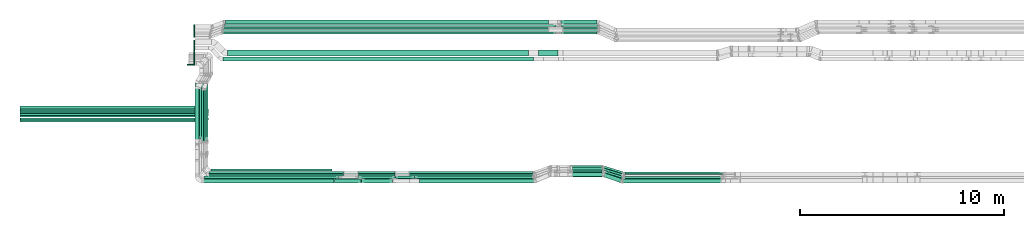
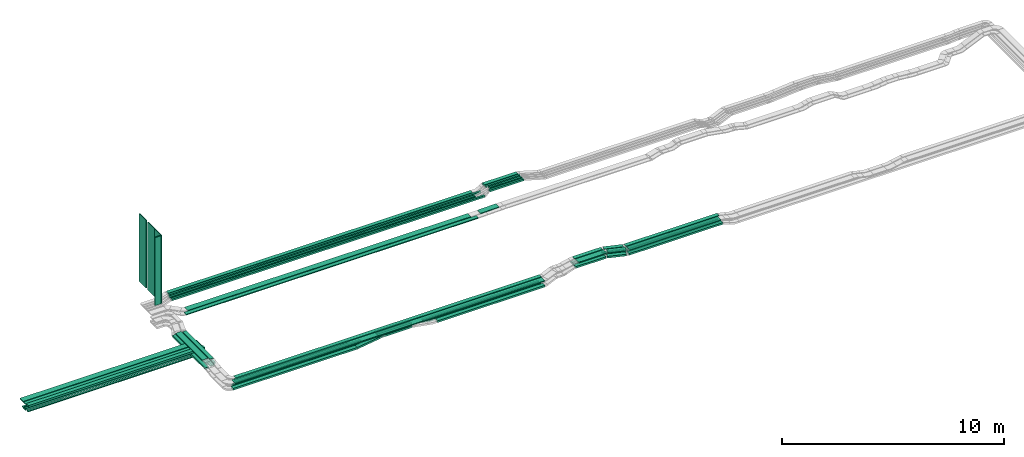
# One storey, part 1 of 31: 65 flow segments.
"""IFC2X3 building model written with IfcOpenShell, lengths in millimetres."""

from ifc_helpers import new_model, entity, si_unit, converted_unit, derived_unit, direction, frame, frame_2d, origin, origin_2d_with_axis, place, context, subcontext, project, spatial, rectangle, extrude, type_object, element, save


model = new_model("IFC2X3")

# Units and contexts
model_context = context("Model", 3, precision=0.01, world=origin(), true_north=direction((6.12303176911189e-17, 1.0)))
body_context = subcontext(model_context, "Body", "Model", "MODEL_VIEW")
ifc_project = project(units=[si_unit("LENGTHUNIT", "METRE", prefix="MILLI"), si_unit("AREAUNIT", "SQUARE_METRE"), si_unit("VOLUMEUNIT", "CUBIC_METRE"), converted_unit("PLANEANGLEUNIT", "DEGREE", entity("IfcRatioMeasure", 0.0174532925199433), si_unit("PLANEANGLEUNIT", "RADIAN"), dimensions=[0, 0, 0, 0, 0, 0, 0]), si_unit("MASSUNIT", "GRAM", prefix="KILO"), derived_unit("MASSDENSITYUNIT", [(si_unit("MASSUNIT", "GRAM", prefix="KILO"), 1), (si_unit("LENGTHUNIT", "METRE"), -3)]), derived_unit("MOMENTOFINERTIAUNIT", [(si_unit("LENGTHUNIT", "METRE"), 4)]), si_unit("TIMEUNIT", "SECOND"), si_unit("FREQUENCYUNIT", "HERTZ"), si_unit("THERMODYNAMICTEMPERATUREUNIT", "DEGREE_CELSIUS"), derived_unit("THERMALTRANSMITTANCEUNIT", [(si_unit("MASSUNIT", "GRAM", prefix="KILO"), 1), (si_unit("THERMODYNAMICTEMPERATUREUNIT", "KELVIN"), -1), (si_unit("TIMEUNIT", "SECOND"), -3)]), derived_unit("VOLUMETRICFLOWRATEUNIT", [(si_unit("LENGTHUNIT", "METRE"), 3), (si_unit("TIMEUNIT", "SECOND"), -1)]), derived_unit("MASSFLOWRATEUNIT", [(si_unit("MASSUNIT", "GRAM", prefix="KILO"), 1), (si_unit("TIMEUNIT", "SECOND"), -1)]), derived_unit("ROTATIONALFREQUENCYUNIT", [(si_unit("TIMEUNIT", "SECOND"), -1)]), si_unit("ELECTRICCURRENTUNIT", "AMPERE"), si_unit("ELECTRICVOLTAGEUNIT", "VOLT"), si_unit("POWERUNIT", "WATT"), si_unit("FORCEUNIT", "NEWTON", prefix="KILO"), si_unit("ILLUMINANCEUNIT", "LUX"), si_unit("LUMINOUSFLUXUNIT", "LUMEN"), si_unit("LUMINOUSINTENSITYUNIT", "CANDELA"), derived_unit("USERDEFINED", [(si_unit("MASSUNIT", "GRAM", prefix="KILO"), -1), (si_unit("LENGTHUNIT", "METRE"), -2), (si_unit("TIMEUNIT", "SECOND"), 3), (si_unit("LUMINOUSFLUXUNIT", "LUMEN"), 1)]), derived_unit("LINEARVELOCITYUNIT", [(si_unit("LENGTHUNIT", "METRE"), 1), (si_unit("TIMEUNIT", "SECOND"), -1)]), si_unit("PRESSUREUNIT", "PASCAL"), derived_unit("USERDEFINED", [(si_unit("LENGTHUNIT", "METRE"), -2), (si_unit("MASSUNIT", "GRAM", prefix="KILO"), 1), (si_unit("TIMEUNIT", "SECOND"), -2)]), derived_unit("LINEARFORCEUNIT", [(si_unit("MASSUNIT", "GRAM", prefix="KILO"), 1), (si_unit("LENGTHUNIT", "METRE"), 1), (si_unit("TIMEUNIT", "SECOND"), -2), (si_unit("LENGTHUNIT", "METRE"), -1)]), derived_unit("PLANARFORCEUNIT", [(si_unit("MASSUNIT", "GRAM", prefix="KILO"), 1), (si_unit("LENGTHUNIT", "METRE"), 1), (si_unit("TIMEUNIT", "SECOND"), -2), (si_unit("LENGTHUNIT", "METRE"), -2)])], contexts=[model_context])

# Site, building, storey
site_placement = place(None, frame((0.0, -0.00077364408347762, 0.0)))
site = spatial("IfcSite", under=ifc_project, at=site_placement, CompositionType="ELEMENT")
building_placement = place(site_placement, origin())
building = spatial("IfcBuilding", under=site, at=building_placement, CompositionType="ELEMENT")
storey_placement = place(building_placement, frame((0.0, 0.0, 15900.0)))
storey = spatial("IfcBuildingStorey", under=building, at=storey_placement, CompositionType="ELEMENT", Elevation=15900.0)

# Flow segments
cable_carrier_segment_type_1 = type_object("IfcCableCarrierSegmentType", PredefinedType="CABLETRAYSEGMENT")
flow_segment_1_placement = place(storey_placement, frame((17073.5, 10315.0806700198, 2607.25805153974)))
element("IfcFlowSegment", 1, at=flow_segment_1_placement, inside=storey, type_object=cable_carrier_segment_type_1, context=body_context, shape_type="SweptSolid", body=[
    extrude(rectangle(XDim=2780.65043288834, YDim=99.9999999999989, at=frame_2d((1.02318153949454e-12, 1.08357767203415e-12), x_axis=(1.0, 0.0))), frame((50.0, 1390.32521644417, 0.0), z_axis=(0.0, 0.0, 1.0), x_axis=(0.0, -1.0, 0.0)), (0.0, 0.0, 1.0), 99.9999999999989),
])
flow_segment_2_placement = place(storey_placement, frame((16853.5, 10214.4421477542, 2607.25805153974)))
element("IfcFlowSegment", 2, at=flow_segment_2_placement, inside=storey, type_object=cable_carrier_segment_type_1, context=body_context, shape_type="SweptSolid", body=[
    extrude(rectangle(XDim=2881.28895515389, YDim=99.9999999999989, at=frame_2d((-1.02318153949454e-12, 0.0), x_axis=(1.0, 0.0))), frame((50.0, 1440.64447757695, 0.0), z_axis=(0.0, 0.0, 1.0), x_axis=(0.0, -1.0, 0.0)), (0.0, 0.0, 1.0), 49.9999999999995),
])
flow_segment_3_placement = place(storey_placement, frame((8000.0, 11314.4937501787, 2532.25805153974)))
element("IfcFlowSegment", 3, at=flow_segment_3_placement, inside=storey, type_object=cable_carrier_segment_type_1, context=body_context, shape_type="SweptSolid", body=[
    extrude(rectangle(XDim=9200.0, YDim=99.9999999999989, at=frame_2d((0.0, -1.08357767203415e-12), x_axis=(1.0, 0.0))), frame((4600.0, 50.0, 0.0)), (0.0, 0.0, 1.0), 50.0000000000016),
])
flow_segment_4_placement = place(storey_placement, frame((7981.51536011307, 11524.4937501787, 2507.25805153974)))
element("IfcFlowSegment", 4, at=flow_segment_4_placement, inside=storey, type_object=cable_carrier_segment_type_1, context=body_context, shape_type="SweptSolid", body=[
    extrude(rectangle(XDim=9218.48463988693, YDim=99.9999999999989, at=frame_2d((4.54747350886464e-13, -1.08357767203415e-12), x_axis=(1.0, 0.0))), frame((4609.24231994347, 50.0, 0.0)), (0.0, 0.0, 1.0), 99.9999999999989),
])
flow_segment_5_placement = place(storey_placement, frame((7981.51536011307, 11638.053841593, 2507.25805153974)))
element("IfcFlowSegment", 5, at=flow_segment_5_placement, inside=storey, type_object=cable_carrier_segment_type_1, context=body_context, shape_type="SweptSolid", body=[
    extrude(rectangle(XDim=9218.48463988694, YDim=99.9999999999989, at=origin_2d_with_axis()), frame((4609.24231994347, 50.0, 0.0)), (0.0, 0.0, 1.0), 50.0000000000016),
])
flow_segment_6_placement = place(storey_placement, frame((8000.0, 11748.053841593, 2507.25805153974)))
element("IfcFlowSegment", 6, at=flow_segment_6_placement, inside=storey, type_object=cable_carrier_segment_type_1, context=body_context, shape_type="SweptSolid", body=[
    extrude(rectangle(XDim=9200.0, YDim=99.9999999999989, at=origin_2d_with_axis()), frame((4600.0, 50.0, 0.0)), (0.0, 0.0, 1.0), 50.0000000000016),
])
flow_segment_7_placement = place(storey_placement, frame((7970.69792091004, 11214.3508300614, 2865.0)))
element("IfcFlowSegment", 7, at=flow_segment_7_placement, inside=storey, type_object=cable_carrier_segment_type_1, context=body_context, shape_type="SweptSolid", body=[
    extrude(rectangle(XDim=9180.0, YDim=200.000000000002, at=frame_2d((-9.09494701772928e-13, -1.08713038571295e-12), x_axis=(1.0, 0.0))), frame((4590.0, 100.0, 0.0)), (0.0, 0.0, 1.0), 100.000000000001),
])
flow_segment_8_placement = place(storey_placement, frame((7970.69792091004, 11450.6171299992, 2865.0)))
element("IfcFlowSegment", 8, at=flow_segment_8_placement, inside=storey, type_object=cable_carrier_segment_type_1, context=body_context, shape_type="SweptSolid", body=[
    extrude(rectangle(XDim=9180.0, YDim=199.999999999998, at=frame_2d((-9.09494701772928e-13, 1.08002495835535e-12), x_axis=(1.0, 0.0))), frame((4590.0, 100.0, 0.0)), (0.0, 0.0, 1.0), 50.0000000000016),
])
flow_segment_9_placement = place(storey_placement, frame((7970.69792091004, 11685.6171299992, 2865.0)))
element("IfcFlowSegment", 9, at=flow_segment_9_placement, inside=storey, type_object=cable_carrier_segment_type_1, context=body_context, shape_type="SweptSolid", body=[
    extrude(rectangle(XDim=9180.0, YDim=300.000000000001, at=frame_2d((-9.09494701772928e-13, 0.0), x_axis=(1.0, 0.0))), frame((4590.0, 150.0, 0.0)), (0.0, 0.0, 1.0), 50.0000000000016),
])
flow_segment_10_placement = place(storey_placement, frame((24529.6232754685, 8454.96624585791, 2685.0)))
element("IfcFlowSegment", 10, at=flow_segment_10_placement, inside=storey, type_object=cable_carrier_segment_type_1, context=body_context, shape_type="SweptSolid", body=[
    extrude(rectangle(XDim=1786.26303875484, YDim=99.9999999999989, at=frame_2d((-2.1600499167107e-12, -5.40012479177676e-13), x_axis=(1.0, 0.0))), frame((893.131519377424, 50.0, 0.0), z_axis=(0.0, 0.0, 1.0), x_axis=(-1.0, 0.0, 0.0)), (0.0, 0.0, 1.0), 99.9999999999989),
])
flow_segment_11_placement = place(storey_placement, frame((24526.241285069, 8695.50215480076, 2685.0)))
element("IfcFlowSegment", 11, at=flow_segment_11_placement, inside=storey, type_object=cable_carrier_segment_type_1, context=body_context, shape_type="SweptSolid", body=[
    extrude(rectangle(XDim=1802.89625010228, YDim=99.9999999999989, at=frame_2d((-2.1600499167107e-12, -1.08357767203415e-12), x_axis=(1.0, 0.0))), frame((901.448125051143, 50.0, 0.0), z_axis=(0.0, 0.0, 1.0), x_axis=(-1.0, 0.0, 0.0)), (0.0, 0.0, 1.0), 50.0000000000016),
])
flow_segment_12_placement = place(storey_placement, frame((27287.2400617418, 8454.96624585788, 2500.0)))
element("IfcFlowSegment", 12, at=flow_segment_12_placement, inside=storey, type_object=cable_carrier_segment_type_1, context=body_context, shape_type="SweptSolid", body=[
    extrude(rectangle(XDim=5758.36690365423, YDim=99.9999999999989, at=frame_2d((-4.32009983342141e-12, -1.08357767203415e-12), x_axis=(1.0, 0.0))), frame((2879.18345182712, 50.0, 0.0)), (0.0, 0.0, 1.0), 99.9999999999968),
])
flow_segment_13_placement = place(storey_placement, frame((27017.8049788234, 8695.50215480076, 2500.0)))
element("IfcFlowSegment", 13, at=flow_segment_13_placement, inside=storey, type_object=cable_carrier_segment_type_1, context=body_context, shape_type="SweptSolid", body=[
    extrude(rectangle(XDim=6063.03813263292, YDim=99.9999999999989, at=frame_2d((-2.27373675443232e-12, 5.40012479177676e-13), x_axis=(1.0, 0.0))), frame((3031.51906631646, 50.0, 0.0)), (0.0, 0.0, 1.0), 50.0000000000016),
])
flow_segment_14_placement = place(storey_placement, frame((26318.6258556337, 8454.96624585791, 2502.07202741318)))
element("IfcFlowSegment", 14, at=flow_segment_14_placement, inside=storey, type_object=cable_carrier_segment_type_1, context=body_context, shape_type="SweptSolid", body=[
    extrude(rectangle(XDim=99.9999999999993, YDim=99.9999999999989, at=frame_2d((-2.1280754936015e-12, 0.0), x_axis=(1.0, 0.0))), frame((9.4705436558692, 50.0, 231.761049279451), z_axis=(0.981897917883988, 0.0, -0.189410873117385), x_axis=(0.189410873117385, 0.0, 0.981897917883988)), (0.0, 0.0, 1.0), 964.391063611438),
])
flow_segment_15_placement = place(storey_placement, frame((37472.0379725514, 8224.96624585787, 2710.0)))
element("IfcFlowSegment", 15, at=flow_segment_15_placement, inside=storey, type_object=cable_carrier_segment_type_1, context=body_context, shape_type="SweptSolid", body=[
    extrude(rectangle(XDim=4888.31327705013, YDim=200.0, at=frame_2d((2.04636307898909e-12, -5.47117906535277e-13), x_axis=(1.0, 0.0))), frame((2444.15663852507, 100.0, 0.0), z_axis=(0.0, 0.0, 1.0), x_axis=(-1.0, 0.0, 0.0)), (0.0, 0.0, 1.0), 99.9999999999968),
])
flow_segment_16_placement = place(storey_placement, frame((37505.9951751335, 8550.14880665484, 2960.0)))
element("IfcFlowSegment", 16, at=flow_segment_16_placement, inside=storey, type_object=cable_carrier_segment_type_1, context=body_context, shape_type="SweptSolid", body=[
    extrude(rectangle(XDim=4857.14151539678, YDim=200.0, at=frame_2d((4.32009983342141e-12, 1.08713038571295e-12), x_axis=(1.0, 0.0))), frame((2428.57075769839, 100.0, 0.0), z_axis=(0.0, 0.0, 1.0), x_axis=(-1.0, 0.0, 0.0)), (0.0, 0.0, 1.0), 50.0000000000016),
])
flow_segment_17_placement = place(storey_placement, frame((37499.7965530135, 8215.14880665484, 2960.0)))
element("IfcFlowSegment", 17, at=flow_segment_17_placement, inside=storey, type_object=cable_carrier_segment_type_1, context=body_context, shape_type="SweptSolid", body=[
    extrude(rectangle(XDim=4763.81493661313, YDim=299.999999999999, at=frame_2d((-4.32009983342141e-12, 5.40012479177676e-13), x_axis=(1.0, 0.0))), frame((2381.90746830657, 150.0, 0.0), z_axis=(0.0, 0.0, 1.0), x_axis=(-1.0, 0.0, 0.0)), (0.0, 0.0, 1.0), 50.0000000000016),
])
flow_segment_18_placement = place(storey_placement, frame((37556.0888944561, 8434.96624585786, 2710.0)))
element("IfcFlowSegment", 18, at=flow_segment_18_placement, inside=storey, type_object=cable_carrier_segment_type_1, context=body_context, shape_type="SweptSolid", body=[
    extrude(rectangle(XDim=4808.31327705014, YDim=99.9999999999989, at=frame_2d((-2.27373675443232e-12, 1.08357767203415e-12), x_axis=(1.0, 0.0))), frame((2404.15663852507, 50.0, 0.0), z_axis=(0.0, 0.0, 1.0), x_axis=(-1.0, 0.0, 0.0)), (0.0, 0.0, 1.0), 99.9999999999989),
])
flow_segment_19_placement = place(storey_placement, frame((37576.499239162, 8654.96624585788, 2710.60211095118)))
element("IfcFlowSegment", 19, at=flow_segment_19_placement, inside=storey, type_object=cable_carrier_segment_type_1, context=body_context, shape_type="SweptSolid", body=[
    extrude(rectangle(XDim=4789.76682509452, YDim=100.000000000001, at=frame_2d((0.0, 5.43565192856477e-13), x_axis=(1.0, 0.0))), frame((2394.88341254726, 50.0, 0.0), z_axis=(0.0, 0.0, 1.0), x_axis=(-1.0, 0.0, 0.0)), (0.0, 0.0, 1.0), 50.0000000000016),
])
flow_segment_20_placement = place(storey_placement, frame((34904.8847391636, 8985.14880665487, 2710.60211095118)))
element("IfcFlowSegment", 20, at=flow_segment_20_placement, inside=storey, type_object=cable_carrier_segment_type_1, context=body_context, shape_type="SweptSolid", body=[
    extrude(rectangle(XDim=1535.81415113666, YDim=100.000000000001, at=frame_2d((2.21689333557151e-12, -5.43565192856477e-13), x_axis=(1.0, 0.0))), frame((767.907075568328, 50.0, 0.0)), (0.0, 0.0, 1.0), 50.0000000000016),
])
flow_segment_21_placement = place(storey_placement, frame((36519.0529819506, 8243.65287049761, 2710.0)))
element("IfcFlowSegment", 21, at=flow_segment_21_placement, inside=storey, type_object=cable_carrier_segment_type_1, context=body_context, shape_type="SweptSolid", body=[
    extrude(rectangle(XDim=885.621574951497, YDim=200.000000000006, at=frame_2d((-2.04636307898909e-12, -6.96331881044898e-13), x_axis=(1.0, 0.0))), frame((451.542171609579, 236.313375360288, 0.0), z_axis=(0.0, 0.0, 1.0), x_axis=(-0.947523036731155, 0.319687495632485, 0.0)), (0.0, 0.0, 1.0), 99.9999999999989),
])
flow_segment_22_placement = place(storey_placement, frame((36528.6751324388, 8567.92914182516, 2960.0)))
element("IfcFlowSegment", 22, at=flow_segment_22_placement, inside=storey, type_object=cable_carrier_segment_type_1, context=body_context, shape_type="SweptSolid", body=[
    extrude(rectangle(XDim=911.680400926984, YDim=200.000000000001, at=frame_2d((1.70530256582424e-13, -5.11590769747272e-13), x_axis=(1.0, 0.0))), frame((464.286871152508, 237.219664829701, 0.0), z_axis=(0.0, 0.0, 1.0), x_axis=(-0.950090398751314, 0.311974733272694, 0.0)), (0.0, 0.0, 1.0), 50.0000000000016),
])
flow_segment_23_placement = place(storey_placement, frame((36540.5349178205, 8239.60370277755, 2960.0)))
element("IfcFlowSegment", 23, at=flow_segment_23_placement, inside=storey, type_object=cable_carrier_segment_type_1, context=body_context, shape_type="SweptSolid", body=[
    extrude(rectangle(XDim=857.94012161665, YDim=299.999999999997, at=origin_2d_with_axis()), frame((454.427085770818, 280.545103877309, 0.0), z_axis=(0.0, 0.0, 1.0), x_axis=(-0.946373728466921, 0.323073932819747, 0.0)), (0.0, 0.0, 1.0), 50.0000000000016),
])
flow_segment_24_placement = place(storey_placement, frame((16963.5, 10214.4421477542, 2607.25805153974)))
element("IfcFlowSegment", 24, at=flow_segment_24_placement, inside=storey, type_object=cable_carrier_segment_type_1, context=body_context, shape_type="SweptSolid", body=[
    extrude(rectangle(XDim=2881.28895515389, YDim=99.9999999999989, at=frame_2d((-1.02318153949454e-12, 0.0), x_axis=(1.0, 0.0))), frame((50.0, 1440.64447757695, 0.0), z_axis=(0.0, 0.0, 1.0), x_axis=(0.0, -1.0, 0.0)), (0.0, 0.0, 1.0), 49.9999999999995),
])
flow_segment_25_placement = place(storey_placement, frame((24526.241285069, 8575.50215480076, 2685.0)))
element("IfcFlowSegment", 25, at=flow_segment_25_placement, inside=storey, type_object=cable_carrier_segment_type_1, context=body_context, shape_type="SweptSolid", body=[
    extrude(rectangle(XDim=1802.89625010228, YDim=100.000000000001, at=frame_2d((-2.1600499167107e-12, 0.0), x_axis=(1.0, 0.0))), frame((901.448125051143, 50.0, 0.0), z_axis=(0.0, 0.0, 1.0), x_axis=(-1.0, 0.0, 0.0)), (0.0, 0.0, 1.0), 50.0000000000016),
])
flow_segment_26_placement = place(storey_placement, frame((27017.8049788234, 8575.50215480076, 2500.0)))
element("IfcFlowSegment", 26, at=flow_segment_26_placement, inside=storey, type_object=cable_carrier_segment_type_1, context=body_context, shape_type="SweptSolid", body=[
    extrude(rectangle(XDim=6046.06785474926, YDim=100.000000000001, at=frame_2d((2.27373675443232e-12, 5.43565192856477e-13), x_axis=(1.0, 0.0))), frame((3023.03392737463, 50.0, 0.0)), (0.0, 0.0, 1.0), 50.0000000000016),
])
flow_segment_27_placement = place(storey_placement, frame((24678.4849941389, 8224.96624585793, 2685.0)))
element("IfcFlowSegment", 27, at=flow_segment_27_placement, inside=storey, type_object=cable_carrier_segment_type_1, context=body_context, shape_type="SweptSolid", body=[
    extrude(rectangle(XDim=1528.31463009343, YDim=200.0, at=frame_2d((0.0, 5.47117906535277e-13), x_axis=(1.0, 0.0))), frame((764.157315046716, 100.0, 0.0), z_axis=(0.0, 0.0, 1.0), x_axis=(-1.0, 0.0, 0.0)), (0.0, 0.0, 1.0), 99.9999999999989),
])
flow_segment_28_placement = place(storey_placement, frame((27523.8169338614, 8224.96624585789, 2500.0)))
element("IfcFlowSegment", 28, at=flow_segment_28_placement, inside=storey, type_object=cable_carrier_segment_type_1, context=body_context, shape_type="SweptSolid", body=[
    extrude(rectangle(XDim=5594.92379897543, YDim=200.0, at=origin_2d_with_axis()), frame((2797.46189948771, 100.0, 0.0), z_axis=(0.0, 0.0, 1.0), x_axis=(-1.0, 0.0, 0.0)), (0.0, 0.0, 1.0), 99.9999999999968),
])
flow_segment_29_placement = place(storey_placement, frame((23349.8865776217, 8224.96624585793, 2501.44360529517)))
element("IfcFlowSegment", 29, at=flow_segment_29_placement, inside=storey, type_object=cable_carrier_segment_type_1, context=body_context, shape_type="SweptSolid", body=[
    extrude(rectangle(XDim=100.000000000002, YDim=200.0, at=origin_2d_with_axis()), frame((6.9201605015629, 100.0, 49.5187982349401), z_axis=(0.990375964698783, 0.0, 0.138403210031255), x_axis=(-0.138403210031255, 0.0, 0.990375964698783)), (0.0, 0.0, 1.0), 1324.96562263443),
])
flow_segment_30_placement = place(storey_placement, frame((36498.8529588234, 8446.30404606326, 2710.0)))
element("IfcFlowSegment", 30, at=flow_segment_30_placement, inside=storey, type_object=cable_carrier_segment_type_1, context=body_context, shape_type="SweptSolid", body=[
    extrude(rectangle(XDim=1027.17142103154, YDim=100.000000000001, at=frame_2d((-4.14956957683899e-12, -1.27897692436818e-12), x_axis=(1.0, 0.0))), frame((505.594720714333, 198.753480193109, 0.0), z_axis=(0.0, 0.0, 1.0), x_axis=(-0.955824550369197, 0.293937797691149, 0.0)), (0.0, 0.0, 1.0), 99.9999999999989),
])
flow_segment_31_placement = place(storey_placement, frame((36486.7453845043, 8556.30404606328, 2710.63734545373)))
element("IfcFlowSegment", 31, at=flow_segment_31_placement, inside=storey, type_object=cable_carrier_segment_type_1, context=body_context, shape_type="SweptSolid", body=[
    extrude(rectangle(XDim=1044.18182268543, YDim=99.9999999999993, at=frame_2d((2.1600499167107e-12, 1.17239551400417e-13), x_axis=(1.0, 0.0))), frame((513.724200470554, 201.253480193111, 0.0), z_axis=(0.0, 0.0, 1.0), x_axis=(0.955824550369191, -0.293937797691166, 0.0)), (0.0, 0.0, 1.0), 50.0000000000016),
])
flow_segment_32_placement = place(storey_placement, frame((36486.7453845043, 8666.30404606327, 2710.60211095119)))
element("IfcFlowSegment", 32, at=flow_segment_32_placement, inside=storey, type_object=cable_carrier_segment_type_1, context=body_context, shape_type="SweptSolid", body=[
    extrude(rectangle(XDim=1061.19222433936, YDim=100.000000000001, at=origin_2d_with_axis()), frame((521.853680226784, 203.753480193106, 0.0), z_axis=(0.0, 0.0, 1.0), x_axis=(-0.955824550369194, 0.293937797691157, 0.0)), (0.0, 0.0, 1.0), 50.0000000000016),
])
flow_segment_33_placement = place(storey_placement, frame((35019.5791049334, 8525.14880665488, 2960.0)))
element("IfcFlowSegment", 33, at=flow_segment_33_placement, inside=storey, type_object=cable_carrier_segment_type_1, context=body_context, shape_type="SweptSolid", body=[
    extrude(rectangle(XDim=1470.54834923566, YDim=299.999999999999, at=frame_2d((0.0, 5.40012479177676e-13), x_axis=(1.0, 0.0))), frame((735.274174617831, 150.0, 0.0), z_axis=(0.0, 0.0, 1.0), x_axis=(-1.0, 0.0, 0.0)), (0.0, 0.0, 1.0), 50.0000000000016),
])
flow_segment_34_placement = place(storey_placement, frame((35014.699398022, 8860.14880665487, 2960.0)))
element("IfcFlowSegment", 34, at=flow_segment_34_placement, inside=storey, type_object=cable_carrier_segment_type_1, context=body_context, shape_type="SweptSolid", body=[
    extrude(rectangle(XDim=1465.22943402716, YDim=200.0, at=frame_2d((0.0, -5.47117906535277e-13), x_axis=(1.0, 0.0))), frame((732.614717013582, 100.0, 0.0), z_axis=(0.0, 0.0, 1.0), x_axis=(-1.0, 0.0, 0.0)), (0.0, 0.0, 1.0), 50.0000000000016),
])
flow_segment_35_placement = place(storey_placement, frame((34902.3799835674, 8870.14880665489, 2710.63734545372)))
element("IfcFlowSegment", 35, at=flow_segment_35_placement, inside=storey, type_object=cable_carrier_segment_type_1, context=body_context, shape_type="SweptSolid", body=[
    extrude(rectangle(XDim=1538.31890673293, YDim=99.9999999999989, at=frame_2d((2.1600499167107e-12, 5.40012479177676e-13), x_axis=(1.0, 0.0))), frame((769.159453366469, 50.0, 0.0), z_axis=(0.0, 0.0, 1.0), x_axis=(-1.0, 0.0, 0.0)), (0.0, 0.0, 1.0), 50.0000000000016),
])
flow_segment_36_placement = place(storey_placement, frame((34899.5720400197, 8755.14880665487, 2710.0)))
element("IfcFlowSegment", 36, at=flow_segment_36_placement, inside=storey, type_object=cable_carrier_segment_type_1, context=body_context, shape_type="SweptSolid", body=[
    extrude(rectangle(XDim=1553.23442459964, YDim=99.9999999999989, at=frame_2d((0.0, 5.40012479177676e-13), x_axis=(1.0, 0.0))), frame((776.617212299821, 50.0, 0.0), z_axis=(0.0, 0.0, 1.0), x_axis=(-1.0, 0.0, 0.0)), (0.0, 0.0, 1.0), 99.9999999999989),
])
flow_segment_37_placement = place(storey_placement, frame((34897.2947679066, 8534.96624585791, 2710.0)))
element("IfcFlowSegment", 37, at=flow_segment_37_placement, inside=storey, type_object=cable_carrier_segment_type_1, context=body_context, shape_type="SweptSolid", body=[
    extrude(rectangle(XDim=1571.85756666243, YDim=200.0, at=frame_2d((0.0, -5.47117906535277e-13), x_axis=(1.0, 0.0))), frame((785.928783331213, 100.0, 0.0), z_axis=(0.0, 0.0, 1.0), x_axis=(-1.0, 0.0, 0.0)), (0.0, 0.0, 1.0), 99.9999999999989),
])
flow_segment_38_placement = place(storey_placement, frame((34443.0813938489, 15514.9939089947, 2834.95683445176)))
element("IfcFlowSegment", 38, at=flow_segment_38_placement, inside=storey, type_object=cable_carrier_segment_type_1, context=body_context, shape_type="SweptSolid", body=[
    extrude(rectangle(XDim=1770.27078387069, YDim=99.9999999999989, at=origin_2d_with_axis()), frame((885.135391935343, 50.0, 0.0), z_axis=(0.0, 0.0, 1.0), x_axis=(-1.0, 0.0, 0.0)), (0.0, 0.0, 1.0), 99.9999999999989),
])
flow_segment_39_placement = place(storey_placement, frame((34544.4393621812, 15629.4580000518, 2838.00113012699)))
element("IfcFlowSegment", 39, at=flow_segment_39_placement, inside=storey, type_object=cable_carrier_segment_type_1, context=body_context, shape_type="SweptSolid", body=[
    extrude(rectangle(XDim=1705.90442705846, YDim=99.9999999999989, at=frame_2d((-2.1600499167107e-12, 1.08357767203415e-12), x_axis=(1.0, 0.0))), frame((852.952213529234, 50.0, 0.0)), (0.0, 0.0, 1.0), 50.0000000000038),
])
flow_segment_40_placement = place(storey_placement, frame((34544.4393621812, 15749.4580000519, 2838.00113012666)))
element("IfcFlowSegment", 40, at=flow_segment_40_placement, inside=storey, type_object=cable_carrier_segment_type_1, context=body_context, shape_type="SweptSolid", body=[
    extrude(rectangle(XDim=1705.9044270585, YDim=99.9999999999989, at=frame_2d((0.0, 1.08357767203415e-12), x_axis=(1.0, 0.0))), frame((852.952213529251, 50.0, 0.0)), (0.0, 0.0, 1.0), 50.0000000000038),
])
flow_segment_41_placement = place(storey_placement, frame((34446.6846508115, 15869.9939089948, 2835.0)))
element("IfcFlowSegment", 41, at=flow_segment_41_placement, inside=storey, type_object=cable_carrier_segment_type_1, context=body_context, shape_type="SweptSolid", body=[
    extrude(rectangle(XDim=1788.24023623879, YDim=99.9999999999989, at=frame_2d((0.0, -1.08357767203415e-12), x_axis=(1.0, 0.0))), frame((894.120118119393, 50.0, 0.0), z_axis=(0.0, 0.0, 1.0), x_axis=(-1.0, 0.0, 0.0)), (0.0, 0.0, 1.0), 99.9999999999989),
])
flow_segment_42_placement = place(storey_placement, frame((34447.9292949519, 15999.9939089947, 2835.0)))
element("IfcFlowSegment", 42, at=flow_segment_42_placement, inside=storey, type_object=cable_carrier_segment_type_1, context=body_context, shape_type="SweptSolid", body=[
    extrude(rectangle(XDim=1748.79198590572, YDim=199.999999999998, at=frame_2d((-2.1600499167107e-12, 1.08002495835535e-12), x_axis=(1.0, 0.0))), frame((874.395992952857, 100.0, 0.0), z_axis=(0.0, 0.0, 1.0), x_axis=(-1.0, 0.0, 0.0)), (0.0, 0.0, 1.0), 99.9999999999989),
])
flow_segment_43_placement = place(storey_placement, frame((33350.191970454, 14435.0255085139, 2654.72987406609)))
element("IfcFlowSegment", 43, at=flow_segment_43_placement, inside=storey, type_object=cable_carrier_segment_type_1, context=body_context, shape_type="SweptSolid", body=[
    extrude(rectangle(XDim=50.0000000000006, YDim=300.000000000001, at=origin_2d_with_axis()), frame((0.472945084256048, 150.0, 24.9955260586229), z_axis=(0.999821042344905, 0.0, 0.0189178033700684), x_axis=(-0.0189178033700684, 0.0, 0.999821042344905)), (0.0, 0.0, 1.0), 956.946818410146),
])
flow_segment_44_placement = place(storey_placement, frame((17896.5126244443, 14200.0255085139, 2650.0)))
element("IfcFlowSegment", 44, at=flow_segment_44_placement, inside=storey, type_object=cable_carrier_segment_type_1, context=body_context, shape_type="SweptSolid", body=[
    extrude(rectangle(XDim=15194.6626405814, YDim=200.000000000002, at=frame_2d((-2.27373675443232e-12, 2.16715534406831e-12), x_axis=(1.0, 0.0))), frame((7597.3313202907, 100.0, 0.0), z_axis=(0.0, 0.0, 1.0), x_axis=(-1.0, 0.0, 0.0)), (0.0, 0.0, 1.0), 50.0000000000016),
])
flow_segment_45_placement = place(storey_placement, frame((18018.6191658148, 15999.9939089947, 2635.0)))
element("IfcFlowSegment", 45, at=flow_segment_45_placement, inside=storey, type_object=cable_carrier_segment_type_1, context=body_context, shape_type="SweptSolid", body=[
    extrude(rectangle(XDim=15812.8789784224, YDim=199.999999999998, at=frame_2d((-2.27373675443232e-12, 1.08002495835535e-12), x_axis=(1.0, 0.0))), frame((7906.43948921119, 100.0, 0.0), z_axis=(0.0, 0.0, 1.0), x_axis=(-1.0, 0.0, 0.0)), (0.0, 0.0, 1.0), 99.9999999999989),
])
flow_segment_46_placement = place(storey_placement, frame((17969.5873403639, 15869.9939089948, 2635.0)))
element("IfcFlowSegment", 46, at=flow_segment_46_placement, inside=storey, type_object=cable_carrier_segment_type_1, context=body_context, shape_type="SweptSolid", body=[
    extrude(rectangle(XDim=16230.3622457112, YDim=99.9999999999989, at=frame_2d((9.09494701772928e-13, -1.08357767203415e-12), x_axis=(1.0, 0.0))), frame((8115.18112285561, 50.0, 0.0), z_axis=(0.0, 0.0, 1.0), x_axis=(-1.0, 0.0, 0.0)), (0.0, 0.0, 1.0), 99.9999999999989),
])
flow_segment_47_placement = place(storey_placement, frame((17929.5873403639, 15749.4580000519, 2638.30690596882)))
element("IfcFlowSegment", 47, at=flow_segment_47_placement, inside=storey, type_object=cable_carrier_segment_type_1, context=body_context, shape_type="SweptSolid", body=[
    extrude(rectangle(XDim=15901.9167428009, YDim=99.9999999999989, at=frame_2d((-1.36424205265939e-12, 1.08357767203415e-12), x_axis=(1.0, 0.0))), frame((7950.95837140046, 50.0, 0.0), z_axis=(0.0, 0.0, 1.0), x_axis=(-1.0, 0.0, 0.0)), (0.0, 0.0, 1.0), 50.0000000000016),
])
flow_segment_48_placement = place(storey_placement, frame((17909.5873403639, 15629.4580000518, 2638.30690596911)))
element("IfcFlowSegment", 48, at=flow_segment_48_placement, inside=storey, type_object=cable_carrier_segment_type_1, context=body_context, shape_type="SweptSolid", body=[
    extrude(rectangle(XDim=15921.9167428008, YDim=99.9999999999989, at=frame_2d((-1.36424205265939e-12, 1.08357767203415e-12), x_axis=(1.0, 0.0))), frame((7960.95837140041, 50.0, 0.0), z_axis=(0.0, 0.0, 1.0), x_axis=(-1.0, 0.0, 0.0)), (0.0, 0.0, 1.0), 50.0000000000016),
])
flow_segment_49_placement = place(storey_placement, frame((17909.5873403639, 15514.9939089948, 2635.0)))
element("IfcFlowSegment", 49, at=flow_segment_49_placement, inside=storey, type_object=cable_carrier_segment_type_1, context=body_context, shape_type="SweptSolid", body=[
    extrude(rectangle(XDim=16286.8021542969, YDim=99.9999999999989, at=frame_2d((-2.27373675443232e-12, 2.16715534406831e-12), x_axis=(1.0, 0.0))), frame((8143.40107714843, 50.0, 0.0), z_axis=(0.0, 0.0, 1.0), x_axis=(-1.0, 0.0, 0.0)), (0.0, 0.0, 1.0), 99.9999999999989),
])
flow_segment_50_placement = place(storey_placement, frame((18117.2554376014, 14435.0255085139, 2650.0)))
element("IfcFlowSegment", 50, at=flow_segment_50_placement, inside=storey, type_object=cable_carrier_segment_type_1, context=body_context, shape_type="SweptSolid", body=[
    extrude(rectangle(XDim=14733.8824230187, YDim=300.000000000001, at=frame_2d((9.09494701772928e-13, 2.17426077142591e-12), x_axis=(1.0, 0.0))), frame((7366.94121150933, 150.0, 0.0), z_axis=(0.0, 0.0, 1.0), x_axis=(-1.0, 0.0, 0.0)), (0.0, 0.0, 1.0), 50.0000000000016),
])
flow_segment_51_placement = place(storey_placement, frame((16868.5, 10277.096692921, 2927.25805153973)))
element("IfcFlowSegment", 51, at=flow_segment_51_placement, inside=storey, type_object=cable_carrier_segment_type_1, context=body_context, shape_type="SweptSolid", body=[
    extrude(rectangle(XDim=2486.8289313542, YDim=199.999999999998, at=frame_2d((1.02318153949454e-12, 0.0), x_axis=(1.0, 0.0))), frame((100.0, 1243.4144656771, 0.0), z_axis=(0.0, 0.0, 1.0), x_axis=(0.0, -1.0, 0.0)), (0.0, 0.0, 1.0), 50.0000000000016),
])
flow_segment_52_placement = place(storey_placement, frame((16533.5, 10116.6833539765, 2607.25805153974)))
element("IfcFlowSegment", 52, at=flow_segment_52_placement, inside=storey, type_object=cable_carrier_segment_type_1, context=body_context, shape_type="SweptSolid", body=[
    extrude(rectangle(XDim=2965.77768760925, YDim=199.999999999998, at=frame_2d((-1.02318153949454e-12, 0.0), x_axis=(1.0, 0.0))), frame((100.0, 1482.88884380462, 0.0), z_axis=(0.0, 0.0, 1.0), x_axis=(0.0, -1.0, 0.0)), (0.0, 0.0, 1.0), 99.9999999999989),
])
flow_segment_53_placement = place(storey_placement, frame((16743.5, 10374.7355429936, 2607.25805153974)))
element("IfcFlowSegment", 53, at=flow_segment_53_placement, inside=storey, type_object=cable_carrier_segment_type_1, context=body_context, shape_type="SweptSolid", body=[
    extrude(rectangle(XDim=2720.99555991448, YDim=99.9999999999989, at=frame_2d((-1.02318153949454e-12, 1.08357767203415e-12), x_axis=(1.0, 0.0))), frame((50.0, 1360.49777995724, 0.0), z_axis=(0.0, 0.0, 1.0), x_axis=(0.0, -1.0, 0.0)), (0.0, 0.0, 1.0), 99.9999999999989),
])
flow_segment_54_placement = place(storey_placement, frame((16533.4999999999, 10387.5944635327, 2927.25805153973)))
element("IfcFlowSegment", 54, at=flow_segment_54_placement, inside=storey, type_object=cable_carrier_segment_type_1, context=body_context, shape_type="SweptSolid", body=[
    extrude(rectangle(XDim=2432.92202283433, YDim=300.000000000001, at=origin_2d_with_axis()), frame((150.0, 1216.46101141717, 0.0), z_axis=(0.0, 0.0, 1.0), x_axis=(0.0, -1.0, 0.0)), (0.0, 0.0, 1.0), 50.0000000000016),
])
flow_segment_55_placement = place(storey_placement, frame((16884.5, 8224.96624585793, 2500.0)))
element("IfcFlowSegment", 55, at=flow_segment_55_placement, inside=storey, type_object=cable_carrier_segment_type_1, context=body_context, shape_type="SweptSolid", body=[
    extrude(rectangle(XDim=6458.46641712016, YDim=200.0, at=frame_2d((0.0, 5.47117906535277e-13), x_axis=(1.0, 0.0))), frame((3229.23320856008, 100.0, 0.0), z_axis=(0.0, 0.0, 1.0), x_axis=(-1.0, 0.0, 0.0)), (0.0, 0.0, 1.0), 100.000000000001),
])
flow_segment_56_placement = place(storey_placement, frame((16994.5, 8454.96624585792, 2500.0)))
element("IfcFlowSegment", 56, at=flow_segment_56_placement, inside=storey, type_object=cable_carrier_segment_type_1, context=body_context, shape_type="SweptSolid", body=[
    extrude(rectangle(XDim=6590.24096142334, YDim=100.000000000001, at=frame_2d((-1.13686837721616e-12, 0.0), x_axis=(1.0, 0.0))), frame((3295.12048071167, 50.0, 0.0), z_axis=(0.0, 0.0, 1.0), x_axis=(-1.0, 0.0, 0.0)), (0.0, 0.0, 1.0), 99.9999999999989),
])
flow_segment_57_placement = place(storey_placement, frame((17104.5, 8575.50215480076, 2500.0)))
element("IfcFlowSegment", 57, at=flow_segment_57_placement, inside=storey, type_object=cable_carrier_segment_type_1, context=body_context, shape_type="SweptSolid", body=[
    extrude(rectangle(XDim=6707.50276899426, YDim=100.000000000001, at=frame_2d((-2.27373675443232e-12, 0.0), x_axis=(1.0, 0.0))), frame((3353.75138449713, 50.0, 0.0)), (0.0, 0.0, 1.0), 50.0000000000016),
])
flow_segment_58_placement = place(storey_placement, frame((17214.5, 8695.50215480076, 2500.0)))
element("IfcFlowSegment", 58, at=flow_segment_58_placement, inside=storey, type_object=cable_carrier_segment_type_1, context=body_context, shape_type="SweptSolid", body=[
    extrude(rectangle(XDim=6597.50276899426, YDim=100.000000000001, at=frame_2d((9.09494701772928e-13, -5.43565192856477e-13), x_axis=(1.0, 0.0))), frame((3298.75138449713, 50.0, 0.0)), (0.0, 0.0, 1.0), 50.0000000000016),
])
flow_segment_59_placement = place(storey_placement, frame((17324.5, 8809.96624585791, 2500.0)))
element("IfcFlowSegment", 59, at=flow_segment_59_placement, inside=storey, type_object=cable_carrier_segment_type_1, context=body_context, shape_type="SweptSolid", body=[
    extrude(rectangle(XDim=5906.54711844842, YDim=99.9999999999989, at=frame_2d((1.13686837721616e-12, -5.40012479177676e-13), x_axis=(1.0, 0.0))), frame((2953.27355922421, 50.0, 0.0), z_axis=(0.0, 0.0, 1.0), x_axis=(-1.0, 0.0, 0.0)), (0.0, 0.0, 1.0), 99.9999999999989),
])
flow_segment_60_placement = place(storey_placement, frame((16984.4999999999, 8215.14880665485, 2820.0)))
element("IfcFlowSegment", 60, at=flow_segment_60_placement, inside=storey, type_object=cable_carrier_segment_type_1, context=body_context, shape_type="SweptSolid", body=[
    extrude(rectangle(XDim=16115.2198488749, YDim=300.000000000001, at=origin_2d_with_axis()), frame((8057.60992443743, 150.0, 0.0), z_axis=(0.0, 0.0, 1.0), x_axis=(-1.0, 0.0, 0.0)), (0.0, 0.0, 1.0), 50.0000000000016),
])
flow_segment_61_placement = place(storey_placement, frame((17219.4999999999, 8550.14880665486, 2820.0)))
element("IfcFlowSegment", 61, at=flow_segment_61_placement, inside=storey, type_object=cable_carrier_segment_type_1, context=body_context, shape_type="SweptSolid", body=[
    extrude(rectangle(XDim=15888.9744328991, YDim=200.0, at=frame_2d((-9.09494701772928e-13, -5.47117906535277e-13), x_axis=(1.0, 0.0))), frame((7944.48721644956, 100.0, 0.0), z_axis=(0.0, 0.0, 1.0), x_axis=(-1.0, 0.0, 0.0)), (0.0, 0.0, 1.0), 50.0000000000016),
])
cable_carrier_segment_type_2 = type_object("IfcCableCarrierSegmentType", PredefinedType="CABLETRAYSEGMENT")
for number, where in (
    (62, (16472.305766128, 15367.6093717678, 3925.84199571756)),
    (63, (16472.305766128, 14607.6093717678, 3925.84199571755)),
):
    element("IfcFlowSegment", number, at=place(storey_placement, frame(where)), inside=storey, type_object=cable_carrier_segment_type_2, context=body_context, shape_type="SweptSolid", body=[
        extrude(rectangle(XDim=50.0000000000016, YDim=599.999999999998, at=origin_2d_with_axis()), frame((25.0, 300.0, 0.0), z_axis=(0.0, 0.0, 1.0), x_axis=(-1.0, 0.0, 0.0)), (0.0, 0.0, 1.0), 3740.0),
    ])
flow_segment_62_placement = place(storey_placement, frame((16472.305766128, 13987.6093717678, 3925.84199571755)))
element("IfcFlowSegment", 64, at=flow_segment_62_placement, inside=storey, type_object=cable_carrier_segment_type_2, context=body_context, shape_type="SweptSolid", body=[
    extrude(rectangle(XDim=50.0000000000016, YDim=600.000000000002, at=origin_2d_with_axis()), frame((25.0, 300.0, 0.0), z_axis=(0.0, 0.0, 1.0), x_axis=(-1.0, 0.0, 0.0)), (0.0, 0.0, 1.0), 3740.0),
])
flow_segment_63_placement = place(storey_placement, frame((16147.305766128, 13982.6093717678, 3925.84199571755)))
element("IfcFlowSegment", 65, at=flow_segment_63_placement, inside=storey, type_object=cable_carrier_segment_type_2, context=body_context, shape_type="SweptSolid", body=[
    extrude(rectangle(XDim=50.0000000000016, YDim=300.000000000001, at=origin_2d_with_axis()), frame((150.0, 25.0, 0.0), z_axis=(0.0, 0.0, 1.0), x_axis=(0.0, 1.0, 0.0)), (0.0, 0.0, 1.0), 3740.0),
])

save(model, "model.ifc")
